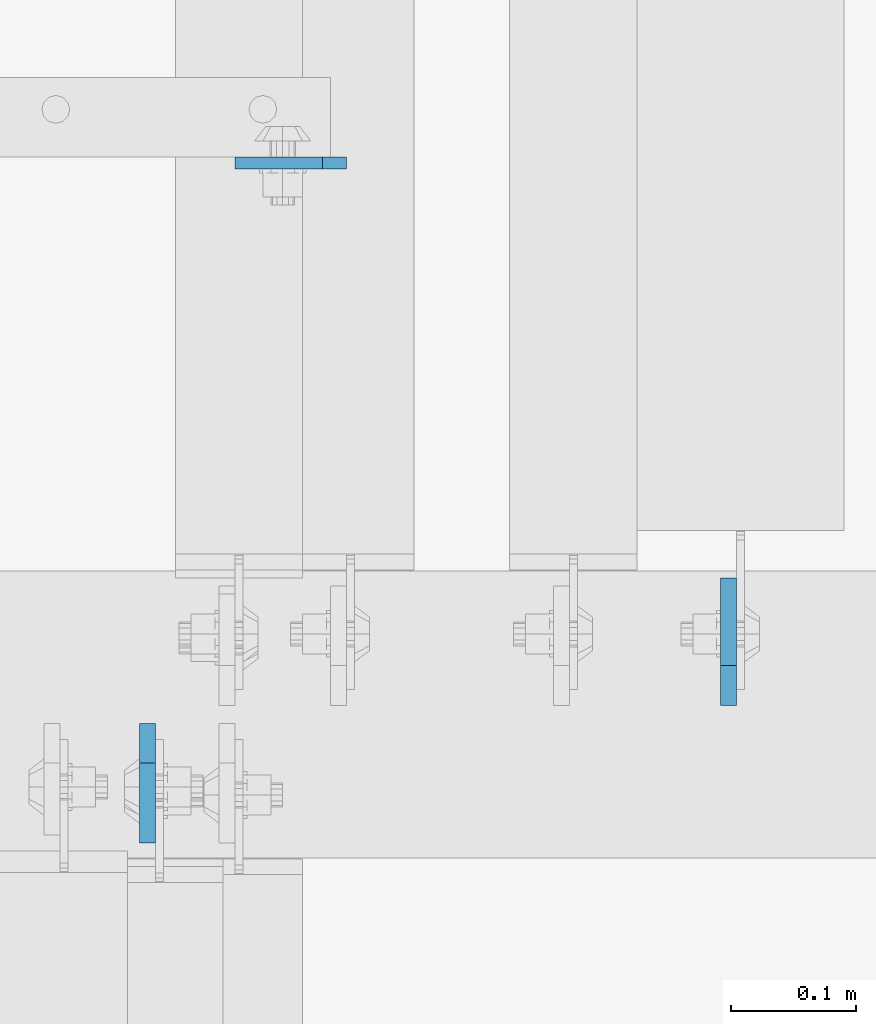
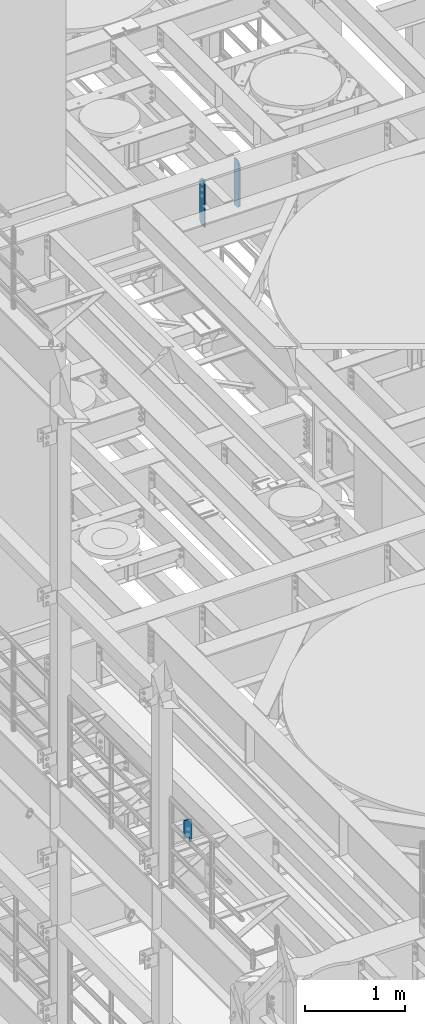
# One storey, part 1563 of 1876: 3 plates, 2 elements without a shape of their own.
"""IFC2X3 building model written with IfcOpenShell, lengths in millimetres."""

import ifcopenshell
import ifcopenshell.guid

model = None  # the IFC model being written
_history = None  # IfcOwnerHistory: only IFC2X3 demands one
_inside = {}  # id of a spatial element -> (the spatial element, [elements in it])
_under = {}  # id of a project, library or spatial element -> (it, [spatial elements below it])
_declared = {}  # id of a project -> (the project, [libraries it declares])
_typed = {}  # id of a type object -> (the type object, [elements of that type])
_made_of = {}  # id of a material, layer set ... -> (it, [elements and type objects made of it])


def new_model(schema):
    """Start an empty IFC model of exactly this schema.

    Asked for "IFC4X3", IfcOpenShell would pick the latest addendum, in which some entities
    have other attributes; the version numbers below select the first issue.
    IFC2X3 requires an IfcOwnerHistory on every rooted entity: one is made here for all.
    """
    global model, _history
    if schema == "IFC4X3":
        model = ifcopenshell.file(schema_version=(4, 3, 0, 0))
    else:
        model = ifcopenshell.file(schema=schema)
    _inside.clear()
    _under.clear()
    _declared.clear()
    _typed.clear()
    _made_of.clear()
    _history = None
    if model.schema == "IFC2X3":
        org = make("IfcOrganization", Name="unknown")
        user = make(
            "IfcPersonAndOrganization",
            ThePerson=make("IfcPerson", FamilyName="unknown"),
            TheOrganization=org,
        )
        app = make(
            "IfcApplication",
            ApplicationDeveloper=org,
            Version="unknown",
            ApplicationFullName="unknown",
            ApplicationIdentifier="unknown",
        )
        _history = make(
            "IfcOwnerHistory",
            OwningUser=user,
            OwningApplication=app,
            ChangeAction="ADDED",
            CreationDate=0,
        )
    return model


def make(cls, **values):
    """One entity of the class cls with the attributes given. An attribute that is None is left unset."""
    return model.create_entity(
        cls, **{name: value for name, value in values.items() if value is not None}
    )


def rooted(cls, **values):
    """An entity with a GlobalId (a new one), such as an element, a storey or a relation."""
    return make(cls, GlobalId=ifcopenshell.guid.new(), OwnerHistory=_history, **values)


def si_unit(unit_type, name, prefix=None):
    """IfcSIUnit, for example si_unit("LENGTHUNIT", "METRE", prefix="MILLI")."""
    return make("IfcSIUnit", UnitType=unit_type, Prefix=prefix, Name=name)


def assignment(units):
    """IfcUnitAssignment: the units of a project."""
    return None if units is None else make("IfcUnitAssignment", Units=units)


def point(xyz):
    """IfcCartesianPoint."""
    return None if xyz is None else make("IfcCartesianPoint", Coordinates=xyz)


def direction(xyz):
    """IfcDirection."""
    return None if xyz is None else make("IfcDirection", DirectionRatios=xyz)


def frame(location, z_axis=None, x_axis=None):
    """IfcAxis2Placement3D, a coordinate frame: its origin and axes. An axis left out is left unset."""
    return make(
        "IfcAxis2Placement3D",
        Location=point(location),
        Axis=direction(z_axis),
        RefDirection=direction(x_axis),
    )


def origin_with_axes():
    """The frame at (0, 0, 0) with the z axis (0, 0, 1) and the x axis (1, 0, 0) written out."""
    return frame((0.0, 0.0, 0.0), z_axis=(0.0, 0.0, 1.0), x_axis=(1.0, 0.0, 0.0))


def place(relative_to, where):
    """IfcLocalPlacement: puts the frame where relative to a parent placement (None: the world)."""
    return make(
        "IfcLocalPlacement", PlacementRelTo=relative_to, RelativePlacement=where
    )


def context(
    kind, dimensions, precision=None, world=None, true_north=None, identifier=None
):
    """IfcGeometricRepresentationContext, for example the 3D "Model" context."""
    return make(
        "IfcGeometricRepresentationContext",
        ContextIdentifier=identifier,
        ContextType=kind,
        CoordinateSpaceDimension=dimensions,
        Precision=precision,
        WorldCoordinateSystem=world,
        TrueNorth=true_north,
    )


def subcontext(parent, identifier, kind, view, scale=None):
    """IfcGeometricRepresentationSubContext, for example "Body" below "Model"."""
    return make(
        "IfcGeometricRepresentationSubContext",
        ContextIdentifier=identifier,
        ContextType=kind,
        ParentContext=parent,
        TargetScale=scale,
        TargetView=view,
    )


def project(units=None, contexts=None):
    """IfcProject with its units and contexts."""
    return rooted(
        "IfcProject",
        Name="project",
        RepresentationContexts=contexts,
        UnitsInContext=assignment(units),
    )


def spatial(cls, under=None, at=None, **own):
    """A site, building, storey or space (cls), placed at a placement, below another one or the project."""
    s = rooted(cls, ObjectPlacement=at, **own)
    if under is not None:
        _under.setdefault(under.id(), (under, []))[1].append(s)
    return s


def faces_of(points, faces, orient=None, outer=None):
    """IfcFace entities. A face is a list of loops; a loop is a list of indices into points, from 0.

    orient and outer hold one flag for each loop. By default every Orientation is true, the
    first loop of a face is its IfcFaceOuterBound and the others are IfcFaceBound.
    """
    made = []
    for i, loops in enumerate(faces):
        bounds = []
        for j, loop in enumerate(loops):
            is_outer = j == 0 if outer is None else outer[i][j]
            bounds.append(
                make(
                    "IfcFaceOuterBound" if is_outer else "IfcFaceBound",
                    Bound=make("IfcPolyLoop", Polygon=[points[k] for k in loop]),
                    Orientation=True if orient is None else orient[i][j],
                )
            )
        made.append(make("IfcFace", Bounds=bounds))
    return made


def faceted_brep(points, faces, orient=None, outer=None, voids=None):
    """IfcFacetedBrep: a solid bounded by flat faces; with voids (closed shells), ...WithVoids."""
    shared = [point(p) for p in points]
    hull = make("IfcClosedShell", CfsFaces=faces_of(shared, faces, orient, outer))
    if voids is None:
        return make("IfcFacetedBrep", Outer=hull)
    return make(
        "IfcFacetedBrepWithVoids",
        Outer=hull,
        Voids=[
            make(cls, CfsFaces=faces_of(shared, fs, o, b)) for cls, fs, o, b in voids
        ],
    )


def shape(context_of_items, identifier, shape_type, items):
    """IfcShapeRepresentation: the items that make up one representation, for example the "Body"."""
    return make(
        "IfcShapeRepresentation",
        ContextOfItems=context_of_items,
        RepresentationIdentifier=identifier,
        RepresentationType=shape_type,
        Items=items,
    )


def material(Name=None, Category=None):
    """IfcMaterial."""
    return make("IfcMaterial", Name=Name, Category=Category)


def made_of(thing, what):
    """Note that an element or type object is made of a material, layer set ...; save() writes the relation."""
    if what is not None:
        _made_of.setdefault(what.id(), (what, []))[1].append(thing)
    return thing


def type_object(cls, material=None, **own):
    """A type object (cls), such as IfcWallType, which elements share."""
    return made_of(rooted(cls, **own), material)


def element(
    cls,
    number,
    at=None,
    inside=None,
    cuts=None,
    type_object=None,
    material=None,
    context=None,
    identifier="Body",
    shape_type=None,
    held_by="IfcProductDefinitionShape",
    body=None,
    shapes=None,
    **own,
):
    """One element of the class cls, such as IfcWall. Its Tag is "e" and its number.

    at: its placement. inside: the storey or other place that contains it. cuts: it is an
    opening in that element (IfcRelVoidsElement). A single representation is given by context,
    identifier, shape_type and body (its items); several are given by shapes. held_by: the class
    of the entity that holds the representations. save() writes the other relations.
    """
    e = rooted(cls, Tag="e%d" % number, ObjectPlacement=at, **own)
    if body is not None:
        shapes = [shape(context, identifier, shape_type, body)]
    if shapes is not None:
        e.Representation = make(held_by, Representations=shapes)
    if inside is not None:
        _inside.setdefault(inside.id(), (inside, []))[1].append(e)
    if cuts is not None:
        rooted(
            "IfcRelVoidsElement", RelatingBuildingElement=cuts, RelatedOpeningElement=e
        )
    if type_object is not None:
        _typed.setdefault(type_object.id(), (type_object, []))[1].append(e)
    return made_of(e, material)


def aggregate(whole, parts):
    """IfcRelAggregates: a whole, such as a stair, and the parts it consists of."""
    return rooted("IfcRelAggregates", RelatingObject=whole, RelatedObjects=parts)


def save(model, path):
    """Write the relations noted so far, then the file.

    IfcRelAggregates (storeys below a building ...), IfcRelContainedInSpatialStructure (elements
    in a storey), IfcRelDefinesByType, IfcRelAssociatesMaterial and IfcRelDeclares: one each for
    every whole, place, type object, material and project.
    """
    for whole, parts in _under.values():
        aggregate(whole, parts)
    for where, things in _inside.values():
        rooted(
            "IfcRelContainedInSpatialStructure",
            RelatedElements=things,
            RelatingStructure=where,
        )
    for kind, things in _typed.values():
        rooted("IfcRelDefinesByType", RelatedObjects=things, RelatingType=kind)
    for what, things in _made_of.values():
        rooted("IfcRelAssociatesMaterial", RelatedObjects=things, RelatingMaterial=what)
    for by, libraries in _declared.values():
        rooted("IfcRelDeclares", RelatingContext=by, RelatedDefinitions=libraries)
    model.write(path)


model = new_model("IFC2X3")

# Units and contexts
model_context = context("Model", 3, precision=1e-05, world=origin_with_axes())
body_context = subcontext(model_context, "Body", "Model", "MODEL_VIEW")
ifc_project = project(units=[si_unit("LENGTHUNIT", "METRE", prefix="MILLI"), si_unit("AREAUNIT", "SQUARE_METRE"), si_unit("VOLUMEUNIT", "CUBIC_METRE"), si_unit("MASSUNIT", "GRAM", prefix="KILO"), si_unit("TIMEUNIT", "SECOND"), si_unit("PLANEANGLEUNIT", "RADIAN"), si_unit("SOLIDANGLEUNIT", "STERADIAN"), si_unit("THERMODYNAMICTEMPERATUREUNIT", "DEGREE_CELSIUS"), si_unit("LUMINOUSINTENSITYUNIT", "LUMEN")], contexts=[model_context])

# Site, building, storey
site_placement = place(None, origin_with_axes())
site = spatial("IfcSite", under=ifc_project, at=site_placement, CompositionType="ELEMENT")
building_placement = place(site_placement, origin_with_axes())
building = spatial("IfcBuilding", under=site, at=building_placement, Name="Undefined", CompositionType="ELEMENT")
storey_placement = place(building_placement, origin_with_axes())
storey = spatial("IfcBuildingStorey", under=building, at=storey_placement, Name="Undefined", CompositionType="ELEMENT", Elevation=0.0)

# Assembly, plate
assembly_1_placement = place(storey_placement, origin_with_axes())
assembly_1 = element("IfcElementAssembly", 1, at=assembly_1_placement, inside=storey, Name="BEAM", AssemblyPlace="NOTDEFINED", PredefinedType="RIGID_FRAME")
ifc_material = material(Name="STEEL/A36")
plate_type_1 = type_object("IfcPlateType", PredefinedType="NOTDEFINED")
plate_1_placement = place(assembly_1_placement, frame((2943.225, 1963.73659114838, 4833.9375), z_axis=(0.0, 0.0, 1.0), x_axis=(-1.0, 0.0, 0.0)))
plate_1 = element("IfcPlate", 2, at=plate_1_placement, type_object=plate_type_1, material=ifc_material, Name="PLATE", context=body_context, shape_type="Brep", body=[
    faceted_brep([(28.6608544150199, -4.76250000000005, 0.0), (28.660805094572, 4.76250000000005, 0.0), (28.660805094572, 4.76250000000005, 58.7375001907349), (28.6608544150199, -4.76250000000005, 58.7375001907349), (29.6275350171727, 4.76250000000005, 63.5975797087804), (29.6275843376211, -4.76250000000005, 63.5975797087804), (32.3805489176884, 4.76250000000005, 67.717756176934), (32.3805982381364, -4.76250000000005, 67.717756176934), (36.500725385898, 4.76250000000005, 70.4707700774125), (36.5007747063464, -4.76250000000005, 70.4707700774125), (41.3608049040099, 4.76250000000005, 71.4375), (41.3608542244583, -4.76250000000005, 71.4375), (88.9000283049895, -4.76249999986135, 71.4375), (88.9000015258789, 4.76250000000005, 71.4375), (19.0499992370605, -4.76249999999982, 0.0), (0.0, -4.76249999999982, 19.0499992370605), (0.0, 4.76249999999982, 19.0499992370605), (19.0499992370605, 4.76249999999982, 0.0), (0.0, -4.76249999999982, 271.462512969971), (0.0, 4.76249999999982, 271.462512969971), (19.0499992370605, -4.76249999999982, 290.512512207031), (19.0499992370605, 4.76249999999982, 290.512512207031), (88.9000015258789, -4.76249999999982, 290.512512207031), (88.9000015258789, 4.76249999999982, 290.512512207031)], [[[0, 1, 2, 3]], [[3, 2, 4, 5]], [[5, 4, 6, 7]], [[7, 6, 8, 9]], [[9, 8, 10, 11]], [[12, 11, 10, 13]], [[14, 15, 16, 17]], [[15, 18, 19, 16]], [[18, 20, 21, 19]], [[20, 22, 23, 21]], [[23, 22, 12, 13]], [[8, 6, 4, 2, 1, 17, 16, 19, 21, 23, 13, 10]], [[14, 17, 1, 0]], [[22, 20, 18, 15, 14, 0, 3, 5, 7, 9, 11, 12]]]),
])
aggregate(assembly_1, [plate_1])

# Assembly, plates
assembly_2_placement = place(storey_placement, origin_with_axes())
assembly_2 = element("IfcElementAssembly", 3, at=assembly_2_placement, inside=storey, Name="BEAM", AssemblyPlace="NOTDEFINED", PredefinedType="RIGID_FRAME")
plate_type_2 = type_object("IfcPlateType", PredefinedType="NOTDEFINED")
plate_2_placement = place(assembly_2_placement, frame((2784.47499990463, 1516.85625, 12714.2875), z_axis=(0.0, 0.0, 1.0), x_axis=(0.0, -1.0, 0.0)))
plate_2 = element("IfcPlate", 4, at=plate_2_placement, type_object=plate_type_2, material=ifc_material, Name="PLATE", context=body_context, shape_type="Brep", body=[
    faceted_brep([(0.0, -6.34999999999991, 31.75), (0.0, -6.35000000000036, 538.162475585938), (0.0, 6.35000000000036, 538.162475585938), (0.0, 6.34999999999991, 31.75), (31.75, -6.35000000000036, 569.912475585938), (31.75, 6.35000000000036, 569.912475585938), (95.25, -6.35000000000036, 569.912475585938), (95.25, 6.35000000000036, 569.912475585938), (95.25, -6.35000000000036, 0.0), (95.25, 6.35000000000036, 0.0), (31.75, -6.34999999999991, 0.0), (31.75, 6.34999999999991, 0.0)], [[[0, 1, 2, 3]], [[1, 4, 5, 2]], [[4, 6, 7, 5]], [[6, 8, 9, 7]], [[8, 10, 11, 9]], [[10, 0, 3, 11]], [[5, 7, 9, 11, 3, 2]], [[10, 8, 6, 4, 1, 0]]]),
])
plate_type_3 = type_object("IfcPlateType", PredefinedType="NOTDEFINED")
plate_3_placement = place(assembly_2_placement, frame((3248.02499990463, 1531.14375, 12714.2875), z_axis=(0.0, 0.0, 1.0), x_axis=(0.0, 1.0, 0.0)))
plate_3 = element("IfcPlate", 5, at=plate_3_placement, type_object=plate_type_3, material=ifc_material, Name="PLATE", context=body_context, shape_type="Brep", body=[
    faceted_brep([(0.0, -6.34999999999991, 31.75), (0.0, -6.35000000000036, 538.162475585938), (0.0, 6.35000000000036, 538.162475585938), (0.0, 6.34999999999991, 31.75), (31.75, -6.35000000000036, 569.912475585938), (31.75, 6.35000000000036, 569.912475585938), (101.599998474121, -6.34999999999991, 569.912475585938), (101.599998474121, 6.34999999999991, 569.912475585938), (101.599998474121, -6.35000000000036, 0.0), (101.599998474121, 6.35000000000036, 0.0), (31.75, -6.34999999999991, 0.0), (31.75, 6.34999999999991, 0.0)], [[[0, 1, 2, 3]], [[1, 4, 5, 2]], [[4, 6, 7, 5]], [[6, 8, 9, 7]], [[8, 10, 11, 9]], [[10, 0, 3, 11]], [[5, 7, 9, 11, 3, 2]], [[10, 8, 6, 4, 1, 0]]]),
])
aggregate(assembly_2, [plate_3, plate_2])

save(model, "model.ifc")
